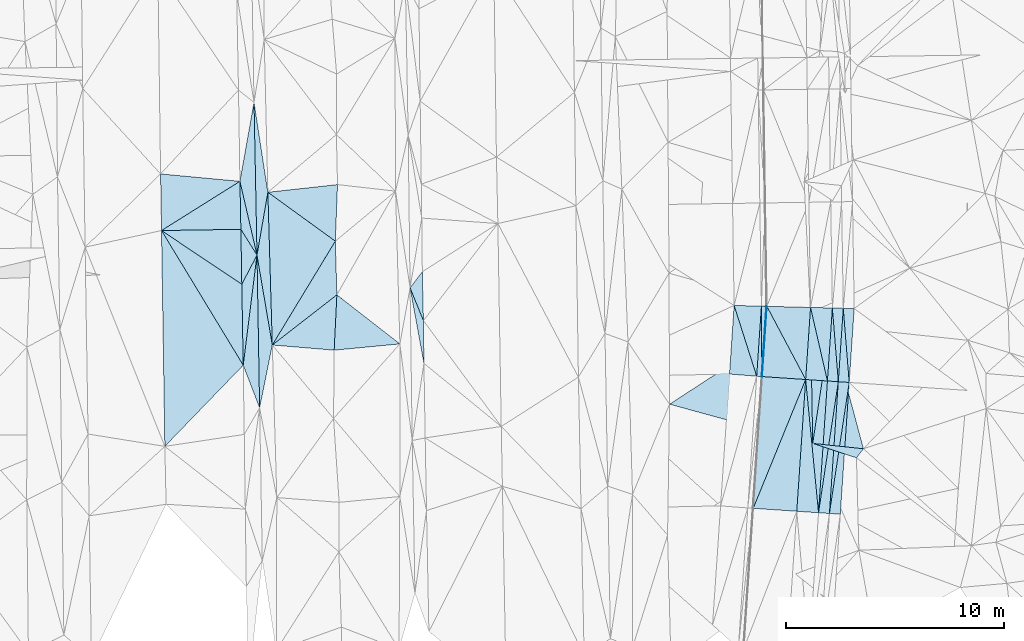
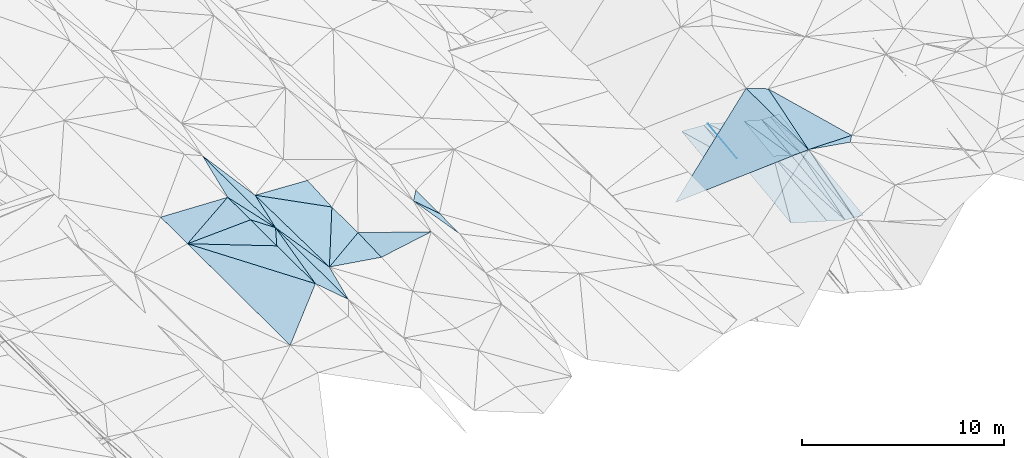
# One storey, part 25 of 275: 46 plates.
"""IFC2X3 building model written with IfcOpenShell, lengths in millimetres."""

from ifc_helpers import new_model, si_unit, frame, origin_with_axes, place, context, subcontext, project, spatial, polyline, outline, extrude, material, type_object, element, save


model = new_model("IFC2X3")

# Units and contexts
model_context = context("Model", 3, precision=1e-05, world=origin_with_axes())
body_context = subcontext(model_context, "Body", "Model", "MODEL_VIEW")
ifc_project = project(units=[si_unit("LENGTHUNIT", "METRE", prefix="MILLI"), si_unit("AREAUNIT", "SQUARE_METRE"), si_unit("VOLUMEUNIT", "CUBIC_METRE"), si_unit("MASSUNIT", "GRAM", prefix="KILO"), si_unit("TIMEUNIT", "SECOND"), si_unit("PLANEANGLEUNIT", "RADIAN"), si_unit("SOLIDANGLEUNIT", "STERADIAN"), si_unit("THERMODYNAMICTEMPERATUREUNIT", "DEGREE_CELSIUS"), si_unit("LUMINOUSINTENSITYUNIT", "LUMEN")], contexts=[model_context])

# Site, building, storey
site_placement = place(None, origin_with_axes())
site = spatial("IfcSite", under=ifc_project, at=site_placement, CompositionType="ELEMENT")
building_placement = place(site_placement, origin_with_axes())
building = spatial("IfcBuilding", under=site, at=building_placement, Name="Undefined", CompositionType="ELEMENT")
storey_placement = place(building_placement, origin_with_axes())
storey = spatial("IfcBuildingStorey", under=building, at=storey_placement, Name="Undefined", CompositionType="ELEMENT", Elevation=0.0)

# Plates
ifc_material = material()
plate_type_1 = type_object("IfcPlateType", PredefinedType="NOTDEFINED")
plate_1_placement = place(storey_placement, frame((-55586.1552944369, -14292.6753610343, 40611.3366836447), z_axis=(-0.0486581063088258, 0.01934422527948, -0.998628153838442), x_axis=(0.0611904169452032, 0.997992182883383, 0.0163504060418234)))
element("IfcPlate", 1, at=plate_1_placement, inside=storey, type_object=plate_type_1, material=ifc_material, Name="00_PR", context=body_context, shape_type="SweptSolid", body=[
    extrude(outline(polyline([(0.0, 0.0), (3227.38159179688, 1.38243194669485e-09), (3228.07495117188, 20.0292549133301), (0.0, 0.0)])), frame((-8.85201319254618e-08, 2.18876761149539e-07, -0.5000001331573), z_axis=(0.0, 0.0, 1.0), x_axis=(1.0, 0.0, 0.0)), (0.0, 0.0, 1.0), 1.0),
])
plate_2_placement = place(storey_placement, frame((-55606.1101675058, -14291.3279053149, 40612.3366855818), z_axis=(-0.0487376757038436, 0.0193490382436612, -0.998624180403235), x_axis=(0.0673750229654271, 0.997598764230324, 0.0160409440662907)))
element("IfcPlate", 2, at=plate_2_placement, inside=storey, type_object=plate_type_1, material=ifc_material, Name="00_PR", context=body_context, shape_type="SweptSolid", body=[
    extrude(outline(polyline([(0.0, 0.0), (3227.3037109375, 2.77213985100389e-09), (-0.015802064910531, 20.0252532958984), (0.0, 0.0)])), frame((-8.85201319254618e-08, 2.18876761149539e-07, -0.5000001331573), z_axis=(0.0, 0.0, 1.0), x_axis=(1.0, 0.0, 0.0)), (0.0, 0.0, 1.0), 1.0),
])
plate_type_2 = type_object("IfcPlateType", PredefinedType="NOTDEFINED")
for number, where, z_axis, x_axis, name in (
    (3, (-51595.2220043855, -14562.2102278566, 39861.336077199), (0.00119469310141427, 0.017689428869619, -0.999842816053934), (-0.0673730229274539, -0.997570314612598, -0.017729726036797), "00_PR"),
    (4, (-52501.9740212068, -20567.9913016475, 39753.9970768652), (0.00119469310141427, 0.017689428869619, -0.999842816053934), (0.0673730229281079, 0.997570314612421, 0.0177297260442445), "00_PR"),
):
    element("IfcPlate", number, at=place(storey_placement, frame(where, z_axis=z_axis, x_axis=x_axis)), inside=storey, type_object=plate_type_2, material=ifc_material, Name=name, context=body_context, shape_type="SweptSolid", body=[
        extrude(outline(polyline([(0.0, 0.0), (6054.1826171875, -3.41970007866621e-09), (6054.1826171875, 499.999847412109), (0.0, 0.0)])), frame((-8.85201319254618e-08, 2.18876761149539e-07, -0.5000001331573), z_axis=(0.0, 0.0, 1.0), x_axis=(1.0, 0.0, 0.0)), (0.0, 0.0, 1.0), 1.0),
    ])
plate_3_placement = place(storey_placement, frame((-52094.0854912446, -14528.5192391381, 39861.336063119), z_axis=(0.00108433110725647, 0.0160553293906104, -0.999870516929172), x_axis=(0.0673749129479323, 0.997597950944902, 0.0160919040449277)))
element("IfcPlate", 5, at=plate_3_placement, inside=storey, type_object=plate_type_2, material=ifc_material, Name="00_PR", context=body_context, shape_type="SweptSolid", body=[
    extrude(outline(polyline([(0.0, 0.0), (3374.05712890625, -1.98633642867208e-09), (3.60080957761966e-06, 499.999847412109), (0.0, 0.0)])), frame((-8.85201319254618e-08, 2.18876761149539e-07, -0.5000001331573), z_axis=(0.0, 0.0, 1.0), x_axis=(1.0, 0.0, 0.0)), (0.0, 0.0, 1.0), 1.0),
])
plate_4_placement = place(storey_placement, frame((-52094.0854356988, -14528.5184220547, 39861.3360767848), z_axis=(0.00119469310141427, 0.017689428869619, -0.999842816053934), x_axis=(-0.0673730229274539, -0.997570314612598, -0.017729726036797)))
element("IfcPlate", 6, at=plate_4_placement, inside=storey, type_object=plate_type_2, material=ifc_material, Name="00_PR", context=body_context, shape_type="SweptSolid", body=[
    extrude(outline(polyline([(0.0, 0.0), (6054.1826171875, -3.41970007866621e-09), (6054.1826171875, 499.999847412109), (0.0, 0.0)])), frame((-8.85201319254618e-08, 2.18876761149539e-07, -0.5000001331573), z_axis=(0.0, 0.0, 1.0), x_axis=(1.0, 0.0, 0.0)), (0.0, 0.0, 1.0), 1.0),
])
plate_5_placement = place(storey_placement, frame((-52592.9489230531, -14494.8274356379, 39861.3360628431), z_axis=(0.00108399901464031, 0.0160504176036968, -0.999870596147763), x_axis=(0.0673747099558814, 0.997598044053438, 0.0160869810442106)))
element("IfcPlate", 7, at=plate_5_placement, inside=storey, type_object=plate_type_2, material=ifc_material, Name="00_PR", context=body_context, shape_type="SweptSolid", body=[
    extrude(outline(polyline([(0.0, 0.0), (3353.20825195313, -6.54836185276508e-11), (-0.000100821227533743, 499.999847412109), (0.0, 0.0)])), frame((-8.85201319254618e-08, 2.18876761149539e-07, -0.5000001331573), z_axis=(0.0, 0.0, 1.0), x_axis=(1.0, 0.0, 0.0)), (0.0, 0.0, 1.0), 1.0),
])
plate_6_placement = place(storey_placement, frame((-53000.8374524668, -20534.2994966777, 39753.9970764369), z_axis=(0.00119469310141427, 0.017689428869619, -0.999842816053934), x_axis=(0.0673730229281079, 0.997570314612421, 0.0177297260442445)))
element("IfcPlate", 8, at=plate_6_placement, inside=storey, type_object=plate_type_2, material=ifc_material, Name="00_PR", context=body_context, shape_type="SweptSolid", body=[
    extrude(outline(polyline([(0.0, 0.0), (6054.1826171875, -3.41970007866621e-09), (6054.1826171875, 499.999847412109), (0.0, 0.0)])), frame((-8.85201319254618e-08, 2.18876761149539e-07, -0.5000001331573), z_axis=(0.0, 0.0, 1.0), x_axis=(1.0, 0.0, 0.0)), (0.0, 0.0, 1.0), 1.0),
])
plate_type_3 = type_object("IfcPlateType", PredefinedType="NOTDEFINED")
plate_7_placement = place(storey_placement, frame((-52593.0698593363, -14494.8187100068, 39861.3509987346), z_axis=(-0.240789412339031, 0.0335019264482689, -0.969999010220979), x_axis=(-0.0673730229274539, -0.997570314612598, -0.017729726036797)))
element("IfcPlate", 9, at=plate_7_placement, inside=storey, type_object=plate_type_3, material=ifc_material, Name="00_PR", context=body_context, shape_type="SweptSolid", body=[
    extrude(outline(polyline([(0.0, 0.0), (6054.1826171875, -3.41970007866621e-09), (-4.43198108673096, 1030.76745605469), (0.0, 0.0)])), frame((-8.85201319254618e-08, 2.18876761149539e-07, -0.5000001331573), z_axis=(0.0, 0.0, 1.0), x_axis=(1.0, 0.0, 0.0)), (0.0, 0.0, 1.0), 1.0),
])
plate_8_placement = place(storey_placement, frame((-53998.6853060108, -20466.9079798772, 40004.0119981769), z_axis=(-0.240789412339031, 0.0335019264482689, -0.969999010220979), x_axis=(0.0673730229281079, 0.997570314612421, 0.0177297260442445)))
element("IfcPlate", 10, at=plate_8_placement, inside=storey, type_object=plate_type_3, material=ifc_material, Name="00_PR", context=body_context, shape_type="SweptSolid", body=[
    extrude(outline(polyline([(0.0, 0.0), (6054.18212890625, -1.07684172689915e-09), (-4.43259334564209, 1030.7666015625), (0.0, 0.0)])), frame((-8.85201319254618e-08, 2.18876761149539e-07, -0.5000001331573), z_axis=(0.0, 0.0, 1.0), x_axis=(1.0, 0.0, 0.0)), (0.0, 0.0, 1.0), 1.0),
])
plate_type_4 = type_object("IfcPlateType", PredefinedType="NOTDEFINED")
plate_9_placement = place(storey_placement, frame((-55606.1101675058, -14291.3279053149, 40612.3366855818), z_axis=(-0.0486594808114121, 0.0193438210056599, -0.998628094695951), x_axis=(-0.00393150004809859, 0.999800992056261, 0.0195581080549457)))
element("IfcPlate", 11, at=plate_9_placement, inside=storey, type_object=plate_type_4, material=ifc_material, Name="00_PR", context=body_context, shape_type="SweptSolid", body=[
    extrude(outline(polyline([(0.0, 0.0), (3226.13012695313, -2.7648638933897e-09), (3219.07104492188, 230.3701171875), (0.0, 0.0)])), frame((-8.85201319254618e-08, 2.18876761149539e-07, -0.5000001331573), z_axis=(0.0, 0.0, 1.0), x_axis=(1.0, 0.0, 0.0)), (0.0, 0.0, 1.0), 1.0),
])
plate_10_placement = place(storey_placement, frame((-55835.5873057982, -14275.830118044, 40623.8366848389), z_axis=(-0.0487386176455849, 0.0193434344115876, -0.998624242993911), x_axis=(0.0673749859348105, 0.997598857709666, 0.0160352850505812)))
element("IfcPlate", 12, at=plate_10_placement, inside=storey, type_object=plate_type_4, material=ifc_material, Name="00_PR", context=body_context, shape_type="SweptSolid", body=[
    extrude(outline(polyline([(0.0, 0.0), (3217.71655273438, -3.19414539262652e-09), (-0.183964297175407, 230.287109375), (0.0, 0.0)])), frame((-8.85201319254618e-08, 2.18876761149539e-07, -0.5000001331573), z_axis=(0.0, 0.0, 1.0), x_axis=(1.0, 0.0, 0.0)), (0.0, 0.0, 1.0), 1.0),
])
plate_type_5 = type_object("IfcPlateType", PredefinedType="NOTDEFINED")
plate_11_placement = place(storey_placement, frame((-78737.2938758269, -8726.04492234405, 41149.5004570122), z_axis=(-0.0378411407019367, 0.0210975985305334, -0.999061028869919), x_axis=(-0.0194646045359085, 0.999571856916425, 0.021845641004815)))
element("IfcPlate", 13, at=plate_11_placement, inside=storey, type_object=plate_type_5, material=ifc_material, Name="00", context=body_context, shape_type="SweptSolid", body=[
    extrude(outline(polyline([(0.0, 0.0), (7003.685546875, -3.34694050252438e-10), (2871.19091796875, 553.879577636719), (0.0, 0.0)])), frame((-8.85201319254618e-08, 2.18876761149539e-07, -0.5000001331573), z_axis=(0.0, 0.0, 1.0), x_axis=(1.0, 0.0, 0.0)), (0.0, 0.0, 1.0), 1.0),
])
plate_type_6 = type_object("IfcPlateType", PredefinedType="NOTDEFINED")
plate_12_placement = place(storey_placement, frame((-51366.4908029051, -11175.4608085267, 39915.9810642133), z_axis=(0.0011134054635723, 0.016057650531631, -0.99987044770194), x_axis=(-0.0673748549476486, -0.997597885894276, -0.0160961790513764)))
element("IfcPlate", 14, at=plate_12_placement, inside=storey, type_object=plate_type_6, material=ifc_material, Name="00_PR", context=body_context, shape_type="SweptSolid", body=[
    extrude(outline(polyline([(0.0, 0.0), (3394.9052734375, 3.12866177409887e-09), (20.84814453125, 499.999664306641), (0.0, 0.0)])), frame((-8.85201319254618e-08, 2.18876761149539e-07, -0.5000001331573), z_axis=(0.0, 0.0, 1.0), x_axis=(1.0, 0.0, 0.0)), (0.0, 0.0, 1.0), 1.0),
])
plate_13_placement = place(storey_placement, frame((-51866.7586764237, -11162.5668723229, 39915.6310634918), z_axis=(0.00111727034613197, 0.0160531047546089, -0.999870516384352), x_axis=(-0.0673749129488963, -0.997597950944921, -0.0160919040397307)))
element("IfcPlate", 15, at=plate_13_placement, inside=storey, type_object=plate_type_6, material=ifc_material, Name="00_PR", context=body_context, shape_type="SweptSolid", body=[
    extrude(outline(polyline([(0.0, 0.0), (3374.05712890625, -1.98633642867208e-09), (20.8486671447754, 500.000549316406), (0.0, 0.0)])), frame((-8.85201319254618e-08, 2.18876761149539e-07, -0.5000001331573), z_axis=(0.0, 0.0, 1.0), x_axis=(1.0, 0.0, 0.0)), (0.0, 0.0, 1.0), 1.0),
])
plate_type_7 = type_object("IfcPlateType", PredefinedType="NOTDEFINED")
plate_14_placement = place(storey_placement, frame((-52367.1484588429, -11149.6654104449, 39915.2939817197), z_axis=(-0.240865790831714, 0.0319098229839848, -0.970033728281725), x_axis=(-0.0673747099548488, -0.997598044053499, -0.0160869810446967)))
element("IfcPlate", 16, at=plate_14_placement, inside=storey, type_object=plate_type_7, material=ifc_material, Name="00_PR", context=body_context, shape_type="SweptSolid", body=[
    extrude(outline(polyline([(0.0, 0.0), (3353.20825195313, -6.54836185276508e-11), (37.6723442077637, 1030.75793457031), (0.0, 0.0)])), frame((-8.85201319254618e-08, 2.18876761149539e-07, -0.5000001331573), z_axis=(0.0, 0.0, 1.0), x_axis=(1.0, 0.0, 0.0)), (0.0, 0.0, 1.0), 1.0),
])
plate_type_8 = type_object("IfcPlateType", PredefinedType="NOTDEFINED")
plate_15_placement = place(storey_placement, frame((-55368.7562075951, -11072.2834234652, 40663.1349851879), z_axis=(-0.240906470655529, 0.0318681634494809, -0.970024995840135), x_axis=(0.463370716921715, -0.874418379729756, -0.143805687962066)))
element("IfcPlate", 17, at=plate_15_placement, inside=storey, type_object=plate_type_8, material=ifc_material, Name="00_PR", context=body_context, shape_type="SweptSolid", body=[
    extrude(outline(polyline([(0.0, 0.0), (3837.01098632813, -6.55563781037927e-09), (2722.63037109375, 1734.40295410156), (0.0, 0.0)])), frame((-8.85201319254618e-08, 2.18876761149539e-07, -0.5000001331573), z_axis=(0.0, 0.0, 1.0), x_axis=(1.0, 0.0, 0.0)), (0.0, 0.0, 1.0), 1.0),
])
plate_type_9 = type_object("IfcPlateType", PredefinedType="NOTDEFINED")
plate_16_placement = place(storey_placement, frame((-55586.2513600103, -14292.6682820798, 40611.3509981471), z_axis=(-0.240789412339031, 0.0335019264482689, -0.969999010220979), x_axis=(0.967937486368815, -0.0653717219691512, -0.242535689020827)))
element("IfcPlate", 18, at=plate_16_placement, inside=storey, type_object=plate_type_9, material=ifc_material, Name="00_PR", context=body_context, shape_type="SweptSolid", body=[
    extrude(outline(polyline([(0.0, 0.0), (2061.55224609375, 3.28782334690914e-10), (26.0336284637451, 6054.12646484375), (0.0, 0.0)])), frame((-8.85201319254618e-08, 2.18876761149539e-07, -0.5000001331573), z_axis=(0.0, 0.0, 1.0), x_axis=(1.0, 0.0, 0.0)), (0.0, 0.0, 1.0), 1.0),
])
plate_17_placement = place(storey_placement, frame((-53590.797635223, -14427.4355044196, 40111.3509986331), z_axis=(-0.240789412339031, 0.0335019264482689, -0.969999010220979), x_axis=(-0.0673730229274539, -0.997570314612598, -0.017729726036797)))
element("IfcPlate", 19, at=plate_17_placement, inside=storey, type_object=plate_type_9, material=ifc_material, Name="00_PR", context=body_context, shape_type="SweptSolid", body=[
    extrude(outline(polyline([(0.0, 0.0), (6054.18212890625, -1.07684172689915e-09), (6045.3173828125, 2061.5341796875), (0.0, 0.0)])), frame((-8.85201319254618e-08, 2.18876761149539e-07, -0.5000001331573), z_axis=(0.0, 0.0, 1.0), x_axis=(1.0, 0.0, 0.0)), (0.0, 0.0, 1.0), 1.0),
])
plate_type_10 = type_object("IfcPlateType", PredefinedType="NOTDEFINED")
plate_18_placement = place(storey_placement, frame((-53367.6840996679, -11123.8753073596, 40164.5819800404), z_axis=(-0.240855432338207, 0.0318971376065498, -0.97003671751418), x_axis=(-0.0673750839303762, -0.997598219693165, -0.0160745180457567)))
element("IfcPlate", 20, at=plate_18_placement, inside=storey, type_object=plate_type_10, material=ifc_material, Name="00_PR", context=body_context, shape_type="SweptSolid", body=[
    extrude(outline(polyline([(0.0, 0.0), (3311.5146484375, -7.93079379945993e-10), (75.3404159545898, 2061.51171875), (0.0, 0.0)])), frame((-8.85201319254618e-08, 2.18876761149539e-07, -0.5000001331573), z_axis=(0.0, 0.0, 1.0), x_axis=(1.0, 0.0, 0.0)), (0.0, 0.0, 1.0), 1.0),
])
plate_type_11 = type_object("IfcPlateType", PredefinedType="NOTDEFINED")
plate_19_placement = place(storey_placement, frame((-53590.7976924792, -14427.4363054686, 40111.3509856772), z_axis=(-0.240903988432581, 0.0319002210385851, -0.970024558583423), x_axis=(0.0673750839308246, 0.997598219693064, 0.0160745180501027)))
element("IfcPlate", 21, at=plate_19_placement, inside=storey, type_object=plate_type_11, material=ifc_material, Name="00_PR", context=body_context, shape_type="SweptSolid", body=[
    extrude(outline(polyline([(0.0, 0.0), (3311.5146484375, -7.93079379945993e-10), (-4.01800298690796, 1030.76916503906), (0.0, 0.0)])), frame((-8.85201319254618e-08, 2.18876761149539e-07, -0.5000001331573), z_axis=(0.0, 0.0, 1.0), x_axis=(1.0, 0.0, 0.0)), (0.0, 0.0, 1.0), 1.0),
])
plate_type_12 = type_object("IfcPlateType", PredefinedType="NOTDEFINED")
plate_20_placement = place(storey_placement, frame((-55618.7848091435, -11065.8404184324, 40675.4333194228), z_axis=(-0.030953940603461, 0.0181540690891366, -0.999355934257972), x_axis=(-0.0673749859328252, -0.997598857709791, -0.0160352850511487)))
element("IfcPlate", 22, at=plate_20_placement, inside=storey, type_object=plate_type_12, material=ifc_material, Name="00_PR", context=body_context, shape_type="SweptSolid", body=[
    extrude(outline(polyline([(0.0, 0.0), (3217.71655273438, -3.19414539262652e-09), (51.4577445983887, 1250.64501953125), (0.0, 0.0)])), frame((-8.85201319254618e-08, 2.18876761149539e-07, -0.5000001331573), z_axis=(0.0, 0.0, 1.0), x_axis=(1.0, 0.0, 0.0)), (0.0, 0.0, 1.0), 1.0),
])
plate_type_13 = type_object("IfcPlateType", PredefinedType="NOTDEFINED")
plate_21_placement = place(storey_placement, frame((-57081.835910949, -14178.2590787965, 40663.1953087974), z_axis=(-0.0301198766634824, 0.0184206104872664, -0.999376542720037), x_axis=(0.0673745839591993, 0.997593659006308, 0.0163571680535201)))
element("IfcPlate", 23, at=plate_21_placement, inside=storey, type_object=plate_type_13, material=ifc_material, Name="00_PR", context=body_context, shape_type="SweptSolid", body=[
    extrude(outline(polyline([(0.0, 0.0), (3152.25708007813, 9.31322574615479e-10), (-14.0144033432007, 1250.61254882813), (0.0, 0.0)])), frame((-8.85201319254618e-08, 2.18876761149539e-07, -0.5000001331573), z_axis=(0.0, 0.0, 1.0), x_axis=(1.0, 0.0, 0.0)), (0.0, 0.0, 1.0), 1.0),
])
plate_type_14 = type_object("IfcPlateType", PredefinedType="NOTDEFINED")
plate_22_placement = place(storey_placement, frame((-78618.0465434534, -15727.7156977687, 41022.501341078), z_axis=(-0.0715645558845559, 0.0168704300454151, -0.997293288321509), x_axis=(-0.0170284105431167, 0.999690567330718, 0.0181329210102157)))
element("IfcPlate", 24, at=plate_22_placement, inside=storey, type_object=plate_type_14, material=ifc_material, Name="00", context=body_context, shape_type="SweptSolid", body=[
    extrude(outline(polyline([(0.0, 0.0), (7003.8359375, 3.15776560455561e-09), (2870.55883789063, 632.2578125), (0.0, 0.0)])), frame((-8.85201319254618e-08, 2.18876761149539e-07, -0.5000001331573), z_axis=(0.0, 0.0, 1.0), x_axis=(1.0, 0.0, 0.0)), (0.0, 0.0, 1.0), 1.0),
])
plate_type_15 = type_object("IfcPlateType", PredefinedType="NOTDEFINED")
plate_23_placement = place(storey_placement, frame((-75076.3031435911, -10547.2810279227, 40671.5024935429), z_axis=(-0.0940779993285207, -0.0338057437900339, -0.994990704343084), x_axis=(-0.049090840458714, -0.998050041889206, 0.0385513069559534)))
element("IfcPlate", 25, at=plate_23_placement, inside=storey, type_object=plate_type_15, material=ifc_material, Name="00", context=body_context, shape_type="SweptSolid", body=[
    extrude(outline(polyline([(0.0, 0.0), (2542.06689453125, 3.34694050252438e-10), (2453.86303710938, 2855.7529296875), (0.0, 0.0)])), frame((-8.85201319254618e-08, 2.18876761149539e-07, -0.5000001331573), z_axis=(0.0, 0.0, 1.0), x_axis=(1.0, 0.0, 0.0)), (0.0, 0.0, 1.0), 1.0),
])
plate_type_16 = type_object("IfcPlateType", PredefinedType="NOTDEFINED")
plate_24_placement = place(storey_placement, frame((-78737.2690572671, -8726.04630033562, 41149.5001014751), z_axis=(0.0118003189036133, 0.0183352242693949, -0.999762257751694), x_axis=(0.0170284106750261, -0.999690567327985, -0.0181329210369859)))
element("IfcPlate", 26, at=plate_24_placement, inside=storey, type_object=plate_type_16, material=ifc_material, Name="00", context=body_context, shape_type="SweptSolid", body=[
    extrude(outline(polyline([(0.0, 0.0), (7003.8359375, 3.15776560455561e-09), (5035.7568359375, 717.408386230469), (0.0, 0.0)])), frame((-8.85201319254618e-08, 2.18876761149539e-07, -0.5000001331573), z_axis=(0.0, 0.0, 1.0), x_axis=(1.0, 0.0, 0.0)), (0.0, 0.0, 1.0), 1.0),
])
plate_25_placement = place(storey_placement, frame((-78873.5892186605, -1725.35754871848, 41302.5002008451), z_axis=(0.0194205813640222, 0.0222236534778308, -0.999564380240503), x_axis=(0.0194646046659246, -0.999571856913375, -0.0218456410284925)))
element("IfcPlate", 27, at=plate_25_placement, inside=storey, type_object=plate_type_16, material=ifc_material, Name="00", context=body_context, shape_type="SweptSolid", body=[
    extrude(outline(polyline([(0.0, 0.0), (7003.685546875, -3.34694050252438e-10), (3606.14965820313, 716.627075195313), (0.0, 0.0)])), frame((-8.85201319254618e-08, 2.18876761149539e-07, -0.5000001331573), z_axis=(0.0, 0.0, 1.0), x_axis=(1.0, 0.0, 0.0)), (0.0, 0.0, 1.0), 1.0),
])
plate_type_17 = type_object("IfcPlateType", PredefinedType="NOTDEFINED")
plate_26_placement = place(storey_placement, frame((-71110.001261531, -11728.3766177399, 41169.5003545515), z_axis=(-0.0318429218682717, 0.0215786630794919, -0.9992599209548), x_axis=(-0.376383595809034, 0.925911501192967, 0.0319887599704519)))
element("IfcPlate", 28, at=plate_26_placement, inside=storey, type_object=plate_type_17, material=ifc_material, Name="00", context=body_context, shape_type="SweptSolid", body=[
    extrude(outline(polyline([(0.0, 0.0), (1625.57092285156, 2.29920260608196e-09), (2095.52221679688, 797.362426757813), (0.0, 0.0)])), frame((-8.85201319254618e-08, 2.18876761149539e-07, -0.5000001331573), z_axis=(0.0, 0.0, 1.0), x_axis=(1.0, 0.0, 0.0)), (0.0, 0.0, 1.0), 1.0),
])
plate_type_18 = type_object("IfcPlateType", PredefinedType="NOTDEFINED")
plate_27_placement = place(storey_placement, frame((-78239.8514962346, -5844.86200905395, 41191.5046187978), z_axis=(-0.135647103938014, 0.00602560852648397, -0.990738893571417), x_axis=(0.985021141173175, 0.108268933561097, -0.134205772854374)))
element("IfcPlate", 29, at=plate_27_placement, inside=storey, type_object=plate_type_18, material=ifc_material, Name="00", context=body_context, shape_type="SweptSolid", body=[
    extrude(outline(polyline([(0.0, 0.0), (3241.29125976563, -5.5533746490255e-09), (2861.90234375, 2566.04125976563), (0.0, 0.0)])), frame((-8.85201319254618e-08, 2.18876761149539e-07, -0.5000001331573), z_axis=(0.0, 0.0, 1.0), x_axis=(1.0, 0.0, 0.0)), (0.0, 0.0, 1.0), 1.0),
])
plate_type_19 = type_object("IfcPlateType", PredefinedType="NOTDEFINED")
plate_28_placement = place(storey_placement, frame((-78036.3682395338, -12846.4849304933, 41029.500557501), z_axis=(-0.0423866441064422, 0.0218795588197754, -0.998861680768286), x_axis=(-0.167631766512853, 0.985431868753656, 0.0286988309946402)))
element("IfcPlate", 30, at=plate_28_placement, inside=storey, type_object=plate_type_19, material=ifc_material, Name="00", context=body_context, shape_type="SweptSolid", body=[
    extrude(outline(polyline([(0.0, 0.0), (4181.35498046875, -6.49015419185162e-09), (6938.3818359375, 974.331909179688), (0.0, 0.0)])), frame((-8.85201319254618e-08, 2.18876761149539e-07, -0.5000001331573), z_axis=(0.0, 0.0, 1.0), x_axis=(1.0, 0.0, 0.0)), (0.0, 0.0, 1.0), 1.0),
])
plate_type_20 = type_object("IfcPlateType", PredefinedType="NOTDEFINED")
plate_29_placement = place(storey_placement, frame((-75200.9946107965, -13084.3959009138, 40769.5033591611), z_axis=(0.107383734778052, -0.0436481049906089, -0.99325906813673), x_axis=(0.0490908404580042, 0.998050041889242, -0.0385513069559191)))
element("IfcPlate", 31, at=plate_29_placement, inside=storey, type_object=plate_type_20, material=ifc_material, Name="00", context=body_context, shape_type="SweptSolid", body=[
    extrude(outline(polyline([(0.0, 0.0), (2542.06689453125, 3.34694050252438e-10), (423.995941162109, 3012.75561523438), (0.0, 0.0)])), frame((-8.85201319254618e-08, 2.18876761149539e-07, -0.5000001331573), z_axis=(0.0, 0.0, 1.0), x_axis=(1.0, 0.0, 0.0)), (0.0, 0.0, 1.0), 1.0),
])
plate_type_21 = type_object("IfcPlateType", PredefinedType="NOTDEFINED")
plate_30_placement = place(storey_placement, frame((-79368.7656723271, -13772.3059098786, 41049.500213967), z_axis=(0.0254990304737643, 0.0166164578004967, -0.999536739082192), x_axis=(-0.0177353326646769, 0.999712002735559, 0.0161669280239411)))
element("IfcPlate", 32, at=plate_30_placement, inside=storey, type_object=plate_type_21, material=ifc_material, Name="00", context=body_context, shape_type="SweptSolid", body=[
    extrude(outline(polyline([(0.0, 0.0), (3711.28002929688, 5.82076609134674e-11), (5035.22216796875, 721.152770996094), (0.0, 0.0)])), frame((-8.85201319254618e-08, 2.18876761149539e-07, -0.5000001331573), z_axis=(0.0, 0.0, 1.0), x_axis=(1.0, 0.0, 0.0)), (0.0, 0.0, 1.0), 1.0),
])
plate_type_22 = type_object("IfcPlateType", PredefinedType="NOTDEFINED")
plate_31_placement = place(storey_placement, frame((-50943.0525283606, -17601.5363840905, 42379.5026221896), z_axis=(0.0884757968317983, 0.051746900850469, -0.994733276626127), x_axis=(-0.607751527566006, -0.788415980510516, -0.0950700921259038)))
element("IfcPlate", 33, at=plate_31_placement, inside=storey, type_object=plate_type_22, material=ifc_material, Name="00", context=body_context, shape_type="SweptSolid", body=[
    extrude(outline(polyline([(0.0, 0.0), (525.927734375, 5.42058842256665e-10), (1237.5654296875, 1992.9931640625), (0.0, 0.0)])), frame((-8.85201319254618e-08, 2.18876761149539e-07, -0.5000001331573), z_axis=(0.0, 0.0, 1.0), x_axis=(1.0, 0.0, 0.0)), (0.0, 0.0, 1.0), 1.0),
])
plate_type_23 = type_object("IfcPlateType", PredefinedType="NOTDEFINED")
plate_32_placement = place(storey_placement, frame((-79519.7617118061, -5343.60392096091, 41209.5000667187), z_axis=(0.00208037921659714, 0.0182169497348025, -0.999831893252398), x_axis=(0.225352028622769, -0.974124158726963, -0.0172796579853246)))
element("IfcPlate", 34, at=plate_32_placement, inside=storey, type_object=plate_type_23, material=ifc_material, Name="00", context=body_context, shape_type="SweptSolid", body=[
    extrude(outline(polyline([(0.0, 0.0), (3472.29077148438, 0.0), (2153.88061523438, 453.650024414063), (0.0, 0.0)])), frame((-8.85201319254618e-08, 2.18876761149539e-07, -0.5000001331573), z_axis=(0.0, 0.0, 1.0), x_axis=(1.0, 0.0, 0.0)), (0.0, 0.0, 1.0), 1.0),
])
plate_type_24 = type_object("IfcPlateType", PredefinedType="NOTDEFINED")
plate_33_placement = place(storey_placement, frame((-83114.4444505356, -7599.75656387355, 41029.5004330114), z_axis=(0.037555711239256, 0.0198727231999957, -0.999096913930741), x_axis=(-0.0164261376570591, 0.999679433729701, 0.0192668570227897)))
element("IfcPlate", 35, at=plate_33_placement, inside=storey, type_object=plate_type_24, material=ifc_material, Name="00", context=body_context, shape_type="SweptSolid", body=[
    extrude(outline(polyline([(0.0, 0.0), (2595.13012695313, 2.91038304567337e-11), (2199.85131835938, 3633.8896484375), (0.0, 0.0)])), frame((-8.85201319254618e-08, 2.18876761149539e-07, -0.5000001331573), z_axis=(0.0, 0.0, 1.0), x_axis=(1.0, 0.0, 0.0)), (0.0, 0.0, 1.0), 1.0),
])
plate_type_25 = type_object("IfcPlateType", PredefinedType="NOTDEFINED")
plate_34_placement = place(storey_placement, frame((-52452.9708587081, -11960.3655303175, 42299.5017745741), z_axis=(0.0840282006282406, 0.00836015951065128, -0.996428306117473), x_axis=(0.258533254565336, -0.965905235608319, 0.0136978870010344)))
element("IfcPlate", 36, at=plate_34_placement, inside=storey, type_object=plate_type_25, material=ifc_material, Name="00", context=body_context, shape_type="SweptSolid", body=[
    extrude(outline(polyline([(0.0, 0.0), (5840.31689453125, 6.01721694692969e-09), (4999.048828125, 2189.94482421875), (0.0, 0.0)])), frame((-8.85201319254618e-08, 2.18876761149539e-07, -0.5000001331573), z_axis=(0.0, 0.0, 1.0), x_axis=(1.0, 0.0, 0.0)), (0.0, 0.0, 1.0), 1.0),
])
plate_type_26 = type_object("IfcPlateType", PredefinedType="NOTDEFINED")
plate_35_placement = place(storey_placement, frame((-79476.3556758874, -7543.94561337707, 41169.5001629594), z_axis=(0.0113457163128852, 0.0240068218385509, -0.999647411453938), x_axis=(0.530086351395702, -0.847822327598505, -0.0143443678649445)))
element("IfcPlate", 37, at=plate_35_placement, inside=storey, type_object=plate_type_26, material=ifc_material, Name="00", context=body_context, shape_type="SweptSolid", body=[
    extrude(outline(polyline([(0.0, 0.0), (1394.275390625, -4.83123585581779e-09), (2157.93798828125, 1299.88598632813), (0.0, 0.0)])), frame((-8.85201319254618e-08, 2.18876761149539e-07, -0.5000001331573), z_axis=(0.0, 0.0, 1.0), x_axis=(1.0, 0.0, 0.0)), (0.0, 0.0, 1.0), 1.0),
])
plate_type_27 = type_object("IfcPlateType", PredefinedType="NOTDEFINED")
plate_36_placement = place(storey_placement, frame((-79519.7436736625, -5343.60357152772, 41209.5004360447), z_axis=(0.0381565323995504, 0.0189151086541594, -0.999092737287107), x_axis=(0.0197177336656435, -0.999640422162172, -0.0181724340286251)))
element("IfcPlate", 38, at=plate_36_placement, inside=storey, type_object=plate_type_27, material=ifc_material, Name="00", context=body_context, shape_type="SweptSolid", body=[
    extrude(outline(polyline([(0.0, 0.0), (2201.13598632813, -9.31322574615479e-10), (2187.73388671875, 3641.19775390625), (0.0, 0.0)])), frame((-8.85201319254618e-08, 2.18876761149539e-07, -0.5000001331573), z_axis=(0.0, 0.0, 1.0), x_axis=(1.0, 0.0, 0.0)), (0.0, 0.0, 1.0), 1.0),
])
plate_type_28 = type_object("IfcPlateType", PredefinedType="NOTDEFINED")
plate_37_placement = place(storey_placement, frame((-53268.0545395998, -17355.6405237161, 42185.5001954916), z_axis=(0.02250923653379, 0.0177204883451871, -0.99958957505742), x_axis=(-0.0170800656691006, 0.999703790488875, 0.0173378960348236)))
element("IfcPlate", 39, at=plate_37_placement, inside=storey, type_object=plate_type_28, material=ifc_material, Name="00", context=body_context, shape_type="SweptSolid", body=[
    extrude(outline(polyline([(0.0, 0.0), (5998.4208984375, -6.3664629124105e-09), (5381.73681640625, 907.335571289063), (0.0, 0.0)])), frame((-8.85201319254618e-08, 2.18876761149539e-07, -0.5000001331573), z_axis=(0.0, 0.0, 1.0), x_axis=(1.0, 0.0, 0.0)), (0.0, 0.0, 1.0), 1.0),
])
plate_type_29 = type_object("IfcPlateType", PredefinedType="NOTDEFINED")
plate_38_placement = place(storey_placement, frame((-83114.446764143, -7599.75812778451, 41029.5003229466), z_axis=(0.0329296299650773, 0.0167447328750129, -0.999317393719987), x_axis=(0.830965528211922, -0.556030522344575, 0.0180651361661361)))
element("IfcPlate", 40, at=plate_38_placement, inside=storey, type_object=plate_type_29, material=ifc_material, Name="00", context=body_context, shape_type="SweptSolid", body=[
    extrude(outline(polyline([(0.0, 0.0), (4428.41943359375, -2.91038304567337e-11), (6545.02099609375, 3048.54028320313), (0.0, 0.0)])), frame((-8.85201319254618e-08, 2.18876761149539e-07, -0.5000001331573), z_axis=(0.0, 0.0, 1.0), x_axis=(1.0, 0.0, 0.0)), (0.0, 0.0, 1.0), 1.0),
])
plate_type_30 = type_object("IfcPlateType", PredefinedType="NOTDEFINED")
plate_39_placement = place(storey_placement, frame((-79476.3423037221, -7543.94540287117, 41169.5004944912), z_axis=(0.0380673957174353, 0.0244339987066309, -0.998976402669501), x_axis=(0.0165774946741681, -0.999578879299183, -0.02381702603848)))
element("IfcPlate", 41, at=plate_39_placement, inside=storey, type_object=plate_type_30, material=ifc_material, Name="00", context=body_context, shape_type="SweptSolid", body=[
    extrude(outline(polyline([(0.0, 0.0), (2519.20629882813, -1.00408215075731e-09), (-1.19085133075714, 3641.22216796875), (0.0, 0.0)])), frame((-8.85201319254618e-08, 2.18876761149539e-07, -0.5000001331573), z_axis=(0.0, 0.0, 1.0), x_axis=(1.0, 0.0, 0.0)), (0.0, 0.0, 1.0), 1.0),
])
plate_type_31 = type_object("IfcPlateType", PredefinedType="NOTDEFINED")
plate_40_placement = place(storey_placement, frame((-71721.8350002994, -10223.2399182019, 41221.5002742333), z_axis=(-0.0228215460766522, 0.0252514092373257, -0.999420603833141), x_axis=(0.376383595809656, -0.925911501192615, -0.0319887599733385)))
element("IfcPlate", 42, at=plate_40_placement, inside=storey, type_object=plate_type_31, material=ifc_material, Name="00", context=body_context, shape_type="SweptSolid", body=[
    extrude(outline(polyline([(0.0, 0.0), (1625.57092285156, 2.29920260608196e-09), (3448.64111328125, 715.412536621094), (0.0, 0.0)])), frame((-8.85201319254618e-08, 2.18876761149539e-07, -0.5000001331573), z_axis=(0.0, 0.0, 1.0), x_axis=(1.0, 0.0, 0.0)), (0.0, 0.0, 1.0), 1.0),
])
plate_type_32 = type_object("IfcPlateType", PredefinedType="NOTDEFINED")
plate_41_placement = place(storey_placement, frame((-75147.6460372735, -8085.90562890134, 40754.5052965405), z_axis=(-0.142368585357942, 0.0292381491372597, -0.98938178502447), x_axis=(0.0289469335083085, -0.999013105285842, -0.0336881360066966)))
element("IfcPlate", 43, at=plate_41_placement, inside=storey, type_object=plate_type_32, material=ifc_material, Name="00", context=body_context, shape_type="SweptSolid", body=[
    extrude(outline(polyline([(0.0, 0.0), (2463.775390625, -1.03318598121405e-09), (4662.9921875, 3056.17651367188), (0.0, 0.0)])), frame((-8.85201319254618e-08, 2.18876761149539e-07, -0.5000001331573), z_axis=(0.0, 0.0, 1.0), x_axis=(1.0, 0.0, 0.0)), (0.0, 0.0, 1.0), 1.0),
])
plate_type_33 = type_object("IfcPlateType", PredefinedType="NOTDEFINED")
plate_42_placement = place(storey_placement, frame((-75147.6379375858, -8085.91061336919, 40754.5040789967), z_axis=(-0.126192503499014, 0.0192815649794249, -0.991818367097825), x_axis=(-0.518139703520741, -0.853872532227484, 0.0493249059083049)))
element("IfcPlate", 44, at=plate_42_placement, inside=storey, type_object=plate_type_33, material=ifc_material, Name="00", context=body_context, shape_type="SweptSolid", body=[
    extrude(outline(polyline([(0.0, 0.0), (5575.27685546875, -1.21217453852296e-08), (-289.824371337891, 3832.89111328125), (0.0, 0.0)])), frame((-8.85201319254618e-08, 2.18876761149539e-07, -0.5000001331573), z_axis=(0.0, 0.0, 1.0), x_axis=(1.0, 0.0, 0.0)), (0.0, 0.0, 1.0), 1.0),
])
plate_type_34 = type_object("IfcPlateType", PredefinedType="NOTDEFINED")
plate_43_placement = place(storey_placement, frame((-82961.2577422614, -17492.5941211156, 40839.5004432747), z_axis=(0.0379227488396463, 0.0197754584561121, -0.999084979550436), x_axis=(-0.0154798785818968, 0.999695820954785, 0.0191999719955177)))
element("IfcPlate", 45, at=plate_43_placement, inside=storey, type_object=plate_type_34, material=ifc_material, Name="00", context=body_context, shape_type="SweptSolid", body=[
    extrude(outline(polyline([(0.0, 0.0), (9895.84765625, 1.83936208486557e-08), (3667.57861328125, 3652.33715820313), (0.0, 0.0)])), frame((-8.85201319254618e-08, 2.18876761149539e-07, -0.5000001331573), z_axis=(0.0, 0.0, 1.0), x_axis=(1.0, 0.0, 0.0)), (0.0, 0.0, 1.0), 1.0),
])
plate_type_35 = type_object("IfcPlateType", PredefinedType="NOTDEFINED")
plate_44_placement = place(storey_placement, frame((-53370.3722084473, -11358.9945010729, 42289.5222225866), z_axis=(0.294063587708272, 0.0215961074350077, -0.955541843420682), x_axis=(0.0170800655681371, -0.999703790491231, -0.0173378959984282)))
element("IfcPlate", 46, at=plate_44_placement, inside=storey, type_object=plate_type_35, material=ifc_material, Name="00", context=body_context, shape_type="SweptSolid", body=[
    extrude(outline(polyline([(0.0, 0.0), (5998.4208984375, -6.3664629124105e-09), (4125.34033203125, 6833.7255859375), (0.0, 0.0)])), frame((-8.85201319254618e-08, 2.18876761149539e-07, -0.5000001331573), z_axis=(0.0, 0.0, 1.0), x_axis=(1.0, 0.0, 0.0)), (0.0, 0.0, 1.0), 1.0),
])

save(model, "model.ifc")
